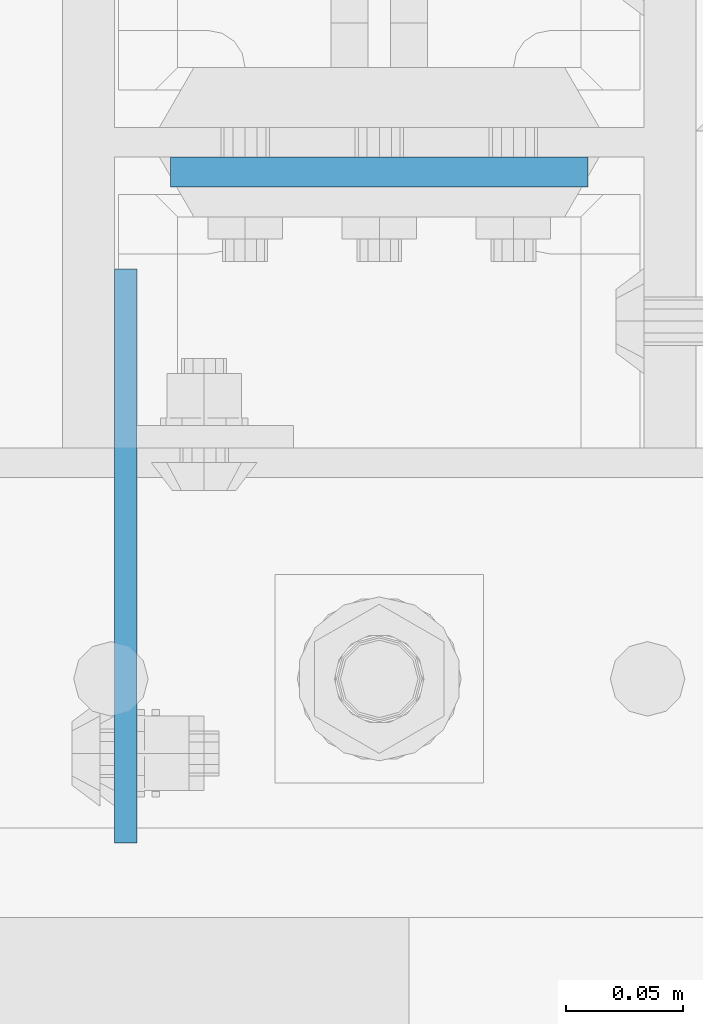
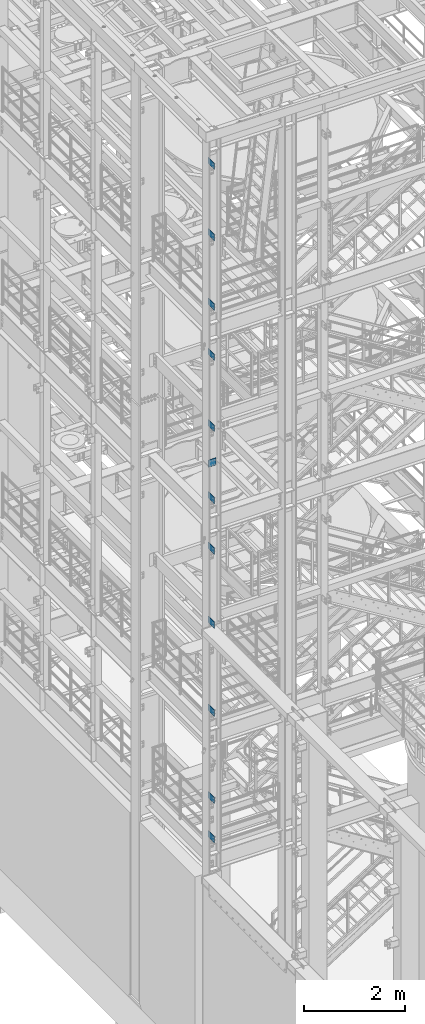
# One storey, part 1123 of 1876: 12 beams, 2 elements without a shape of their own.
"""IFC2X3 building model written with IfcOpenShell, lengths in millimetres."""

from ifc_helpers import new_model, si_unit, frame, origin_with_axes, place, context, subcontext, project, spatial, faceted_brep, material, type_object, element, aggregate, save


model = new_model("IFC2X3")

# Units and contexts
model_context = context("Model", 3, precision=1e-05, world=origin_with_axes())
body_context = subcontext(model_context, "Body", "Model", "MODEL_VIEW")
ifc_project = project(units=[si_unit("LENGTHUNIT", "METRE", prefix="MILLI"), si_unit("AREAUNIT", "SQUARE_METRE"), si_unit("VOLUMEUNIT", "CUBIC_METRE"), si_unit("MASSUNIT", "GRAM", prefix="KILO"), si_unit("TIMEUNIT", "SECOND"), si_unit("PLANEANGLEUNIT", "RADIAN"), si_unit("SOLIDANGLEUNIT", "STERADIAN"), si_unit("THERMODYNAMICTEMPERATUREUNIT", "DEGREE_CELSIUS"), si_unit("LUMINOUSINTENSITYUNIT", "LUMEN")], contexts=[model_context])

# Site, building, storey
site_placement = place(None, origin_with_axes())
site = spatial("IfcSite", under=ifc_project, at=site_placement, CompositionType="ELEMENT")
building_placement = place(site_placement, origin_with_axes())
building = spatial("IfcBuilding", under=site, at=building_placement, Name="Undefined", CompositionType="ELEMENT")
storey_placement = place(building_placement, origin_with_axes())
storey = spatial("IfcBuildingStorey", under=building, at=storey_placement, Name="Undefined", CompositionType="ELEMENT", Elevation=0.0)

# Assembly, beams
assembly_1_placement = place(storey_placement, origin_with_axes())
assembly_1 = element("IfcElementAssembly", 1, at=assembly_1_placement, inside=storey, Name="COLUMN", AssemblyPlace="NOTDEFINED", PredefinedType="RIGID_FRAME")
ifc_material_1 = material(Name="STEEL/A36")
beam_type_1 = type_object("IfcBeamType", PredefinedType="NOTDEFINED")
beam_1_placement = place(assembly_1_placement, frame((-107.949993576915, -7410.44999603976, 21907.5), z_axis=(0.0, 0.0, -1.0), x_axis=(0.0, 1.0, 0.0)))
beam_1 = element("IfcBeam", 2, at=beam_1_placement, type_object=beam_type_1, material=ifc_material_1, Name="PLATE", context=body_context, shape_type="Brep", body=[
    faceted_brep([(0.0, 4.76249999999982, -76.1999999999998), (3.63797880709171e-12, 4.76249999999982, 76.1999969482422), (244.474996168343, 4.76249999995889, 76.1999999999998), (244.474996168343, 4.76249999995889, -76.1999999999998), (3.63797880709171e-12, -4.76249999999982, 76.1999969482422), (244.474996168342, -4.76250000004075, 76.1999999999998), (0.0, -4.76249999999982, -76.1999999999998), (244.474996168342, -4.76250000004075, -76.1999999999998)], [[[0, 1, 2, 3]], [[1, 4, 5, 2]], [[4, 6, 7, 5]], [[6, 0, 3, 7]], [[5, 7, 3, 2]], [[6, 4, 1, 0]]]),
])
beam_2_placement = place(assembly_1_placement, frame((-107.949993576915, -7410.4499960435, 20186.65), z_axis=(0.0, 0.0, -1.0), x_axis=(0.0, 1.0, 0.0)))
beam_2 = element("IfcBeam", 3, at=beam_2_placement, type_object=beam_type_1, material=ifc_material_1, Name="PLATE", context=body_context, shape_type="Brep", body=[
    faceted_brep([(0.0, 4.76249999999982, -76.1999999999998), (3.63797880709171e-12, 4.76249999999982, 76.1999969482422), (244.474996168343, 4.76249999995889, 76.1999999999998), (244.474996168343, 4.76249999995889, -76.1999999999998), (3.63797880709171e-12, -4.76249999999982, 76.1999969482422), (244.474996168342, -4.76250000004075, 76.1999999999998), (0.0, -4.76249999999982, -76.1999999999998), (244.474996168342, -4.76250000004075, -76.1999999999998)], [[[0, 1, 2, 3]], [[1, 4, 5, 2]], [[4, 6, 7, 5]], [[6, 0, 3, 7]], [[5, 7, 3, 2]], [[6, 4, 1, 0]]]),
])
beam_3_placement = place(assembly_1_placement, frame((-107.949993576915, -7410.4499960435, 18503.9), z_axis=(0.0, 0.0, -1.0), x_axis=(0.0, 1.0, 0.0)))
beam_3 = element("IfcBeam", 4, at=beam_3_placement, type_object=beam_type_1, material=ifc_material_1, Name="PLATE", context=body_context, shape_type="Brep", body=[
    faceted_brep([(0.0, 4.76249999999982, -76.1999999999998), (3.63797880709171e-12, 4.76249999999982, 76.1999969482422), (244.474996168343, 4.76249999995889, 76.1999999999998), (244.474996168343, 4.76249999995889, -76.1999999999998), (3.63797880709171e-12, -4.76249999999982, 76.1999969482422), (244.474996168342, -4.76250000004075, 76.1999999999998), (0.0, -4.76249999999982, -76.1999999999998), (244.474996168342, -4.76250000004075, -76.1999999999998)], [[[0, 1, 2, 3]], [[1, 4, 5, 2]], [[4, 6, 7, 5]], [[6, 0, 3, 7]], [[5, 7, 3, 2]], [[6, 4, 1, 0]]]),
])
beam_4_placement = place(assembly_1_placement, frame((-107.949993576915, -7410.44999603976, 17284.7), z_axis=(0.0, 0.0, -1.0), x_axis=(0.0, 1.0, 0.0)))
beam_4 = element("IfcBeam", 5, at=beam_4_placement, type_object=beam_type_1, material=ifc_material_1, Name="PLATE", context=body_context, shape_type="Brep", body=[
    faceted_brep([(0.0, 4.76249999999982, -76.1999999999998), (3.63797880709171e-12, 4.76249999999982, 76.1999969482422), (244.474996168343, 4.76249999995889, 76.1999999999998), (244.474996168343, 4.76249999995889, -76.1999999999998), (3.63797880709171e-12, -4.76249999999982, 76.1999969482422), (244.474996168342, -4.76250000004075, 76.1999999999998), (0.0, -4.76249999999982, -76.1999999999998), (244.474996168342, -4.76250000004075, -76.1999999999998)], [[[0, 1, 2, 3]], [[1, 4, 5, 2]], [[4, 6, 7, 5]], [[6, 0, 3, 7]], [[5, 7, 3, 2]], [[6, 4, 1, 0]]]),
])
beam_5_placement = place(assembly_1_placement, frame((-107.949993576915, -7410.4499960435, 15563.85), z_axis=(0.0, 0.0, -1.0), x_axis=(0.0, 1.0, 0.0)))
beam_5 = element("IfcBeam", 6, at=beam_5_placement, type_object=beam_type_1, material=ifc_material_1, Name="PLATE", context=body_context, shape_type="Brep", body=[
    faceted_brep([(0.0, 4.76249999999982, -76.1999999999998), (3.63797880709171e-12, 4.76249999999982, 76.1999969482422), (244.474996168343, 4.76249999995889, 76.1999999999998), (244.474996168343, 4.76249999995889, -76.1999999999998), (3.63797880709171e-12, -4.76249999999982, 76.1999969482422), (244.474996168342, -4.76250000004075, 76.1999999999998), (0.0, -4.76249999999982, -76.1999999999998), (244.474996168342, -4.76250000004075, -76.1999999999998)], [[[0, 1, 2, 3]], [[1, 4, 5, 2]], [[4, 6, 7, 5]], [[6, 0, 3, 7]], [[5, 7, 3, 2]], [[6, 4, 1, 0]]]),
])
aggregate(assembly_1, [beam_1, beam_2, beam_3, beam_4, beam_5])

assembly_2_placement = place(storey_placement, origin_with_axes())
assembly_2 = element("IfcElementAssembly", 7, at=assembly_2_placement, inside=storey, Name="COLUMN", AssemblyPlace="NOTDEFINED", PredefinedType="RIGID_FRAME")
beam_6_placement = place(assembly_2_placement, frame((-107.949993576915, -7410.4499960435, 13817.6), z_axis=(0.0, 0.0, -1.0), x_axis=(0.0, 1.0, 0.0)))
beam_6 = element("IfcBeam", 8, at=beam_6_placement, type_object=beam_type_1, material=ifc_material_1, Name="PLATE", context=body_context, shape_type="Brep", body=[
    faceted_brep([(0.0, 4.76249999999982, -76.1999999999998), (3.63797880709171e-12, 4.76249999999982, 76.1999969482422), (244.474996168343, 4.76249999995889, 76.1999999999998), (244.474996168343, 4.76249999995889, -76.1999999999998), (3.63797880709171e-12, -4.76249999999982, 76.1999969482422), (244.474996168342, -4.76250000004075, 76.1999999999998), (0.0, -4.76249999999982, -76.1999999999998), (244.474996168342, -4.76250000004075, -76.1999999999998)], [[[0, 1, 2, 3]], [[1, 4, 5, 2]], [[4, 6, 7, 5]], [[6, 0, 3, 7]], [[5, 7, 3, 2]], [[6, 4, 1, 0]]]),
])
beam_7_placement = place(assembly_2_placement, frame((-107.949993576915, -7410.44999603976, 12598.4), z_axis=(0.0, 0.0, -1.0), x_axis=(0.0, 1.0, 0.0)))
beam_7 = element("IfcBeam", 9, at=beam_7_placement, type_object=beam_type_1, material=ifc_material_1, Name="PLATE", context=body_context, shape_type="Brep", body=[
    faceted_brep([(0.0, 4.76249999999982, -76.1999999999998), (3.63797880709171e-12, 4.76249999999982, 76.1999969482422), (244.474996168343, 4.76249999995889, 76.1999999999998), (244.474996168343, 4.76249999995889, -76.1999999999998), (3.63797880709171e-12, -4.76249999999982, 76.1999969482422), (244.474996168342, -4.76250000004075, 76.1999999999998), (0.0, -4.76249999999982, -76.1999999999998), (244.474996168342, -4.76250000004075, -76.1999999999998)], [[[0, 1, 2, 3]], [[1, 4, 5, 2]], [[4, 6, 7, 5]], [[6, 0, 3, 7]], [[5, 7, 3, 2]], [[6, 4, 1, 0]]]),
])
beam_8_placement = place(assembly_2_placement, frame((-107.949993576915, -7410.4499960435, 10801.35), z_axis=(0.0, 0.0, -1.0), x_axis=(0.0, 1.0, 0.0)))
beam_8 = element("IfcBeam", 10, at=beam_8_placement, type_object=beam_type_1, material=ifc_material_1, Name="PLATE", context=body_context, shape_type="Brep", body=[
    faceted_brep([(0.0, 4.76249999999982, -76.1999999999998), (3.63797880709171e-12, 4.76249999999982, 76.1999969482422), (244.474996168343, 4.76249999995889, 76.1999999999998), (244.474996168343, 4.76249999995889, -76.1999999999998), (3.63797880709171e-12, -4.76249999999982, 76.1999969482422), (244.474996168342, -4.76250000004075, 76.1999999999998), (0.0, -4.76249999999982, -76.1999999999998), (244.474996168342, -4.76250000004075, -76.1999999999998)], [[[0, 1, 2, 3]], [[1, 4, 5, 2]], [[4, 6, 7, 5]], [[6, 0, 3, 7]], [[5, 7, 3, 2]], [[6, 4, 1, 0]]]),
])
beam_9_placement = place(assembly_2_placement, frame((-107.949993576915, -7410.4499960435, 8674.1), z_axis=(0.0, 0.0, -1.0), x_axis=(0.0, 1.0, 0.0)))
beam_9 = element("IfcBeam", 11, at=beam_9_placement, type_object=beam_type_1, material=ifc_material_1, Name="PLATE", context=body_context, shape_type="Brep", body=[
    faceted_brep([(0.0, 4.76249999999982, -76.1999999999998), (3.63797880709171e-12, 4.76249999999982, 76.1999969482422), (244.474996168343, 4.76249999995889, 76.1999999999998), (244.474996168343, 4.76249999995889, -76.1999999999998), (3.63797880709171e-12, -4.76249999999982, 76.1999969482422), (244.474996168342, -4.76250000004075, 76.1999999999998), (0.0, -4.76249999999982, -76.1999999999998), (244.474996168342, -4.76250000004075, -76.1999999999998)], [[[0, 1, 2, 3]], [[1, 4, 5, 2]], [[4, 6, 7, 5]], [[6, 0, 3, 7]], [[5, 7, 3, 2]], [[6, 4, 1, 0]]]),
])
beam_10_placement = place(assembly_2_placement, frame((-107.949993576915, -7410.4499960435, 6559.55), z_axis=(0.0, 0.0, -1.0), x_axis=(0.0, 1.0, 0.0)))
beam_10 = element("IfcBeam", 12, at=beam_10_placement, type_object=beam_type_1, material=ifc_material_1, Name="PLATE", context=body_context, shape_type="Brep", body=[
    faceted_brep([(0.0, 4.76249999999982, -76.1999999999998), (3.63797880709171e-12, 4.76249999999982, 76.1999969482422), (244.474996168343, 4.76249999995889, 76.1999999999998), (244.474996168343, 4.76249999995889, -76.1999999999998), (3.63797880709171e-12, -4.76249999999982, 76.1999969482422), (244.474996168342, -4.76250000004075, 76.1999999999998), (0.0, -4.76249999999982, -76.1999999999998), (244.474996168342, -4.76250000004075, -76.1999999999998)], [[[0, 1, 2, 3]], [[1, 4, 5, 2]], [[4, 6, 7, 5]], [[6, 0, 3, 7]], [[5, 7, 3, 2]], [[6, 4, 1, 0]]]),
])
beam_11_placement = place(assembly_2_placement, frame((-107.949993576915, -7410.4499960435, 5613.4), z_axis=(0.0, 0.0, -1.0), x_axis=(0.0, 1.0, 0.0)))
beam_11 = element("IfcBeam", 13, at=beam_11_placement, type_object=beam_type_1, material=ifc_material_1, Name="PLATE", context=body_context, shape_type="Brep", body=[
    faceted_brep([(0.0, 4.76249999999982, -76.1999999999998), (3.63797880709171e-12, 4.76249999999982, 76.1999969482422), (244.474996168343, 4.76249999995889, 76.1999999999998), (244.474996168343, 4.76249999995889, -76.1999999999998), (3.63797880709171e-12, -4.76249999999982, 76.1999969482422), (244.474996168342, -4.76250000004075, 76.1999999999998), (0.0, -4.76249999999982, -76.1999999999998), (244.474996168342, -4.76250000004075, -76.1999999999998)], [[[0, 1, 2, 3]], [[1, 4, 5, 2]], [[4, 6, 7, 5]], [[6, 0, 3, 7]], [[5, 7, 3, 2]], [[6, 4, 1, 0]]]),
])
ifc_material_2 = material(Name="STEEL/A572-50")
beam_type_2 = type_object("IfcBeamType", PredefinedType="NOTDEFINED")
beam_12_placement = place(assembly_2_placement, frame((0.0, -7124.7, 14617.7), z_axis=(-1.0, 0.0, 0.0), x_axis=(0.0, 0.0, -1.0)))
beam_12 = element("IfcBeam", 14, at=beam_12_placement, type_object=beam_type_2, material=ifc_material_2, Name="PLATE", context=body_context, shape_type="Brep", body=[
    faceted_brep([(0.0, 6.35000000000036, -88.9), (0.0, 6.35000000000036, 88.9), (171.449999999999, 6.35000000000036, 88.9), (171.449999999999, 6.35000000000036, -88.9), (0.0, -6.35000000000036, 88.9), (171.449999999999, -6.35000000000036, 88.9), (0.0, -6.35000000000036, -88.9), (171.449999999999, -6.35000000000036, -88.9)], [[[0, 1, 2, 3]], [[1, 4, 5, 2]], [[4, 6, 7, 5]], [[6, 0, 3, 7]], [[5, 7, 3, 2]], [[6, 4, 1, 0]]]),
])
aggregate(assembly_2, [beam_6, beam_7, beam_8, beam_9, beam_10, beam_11, beam_12])

save(model, "model.ifc")
